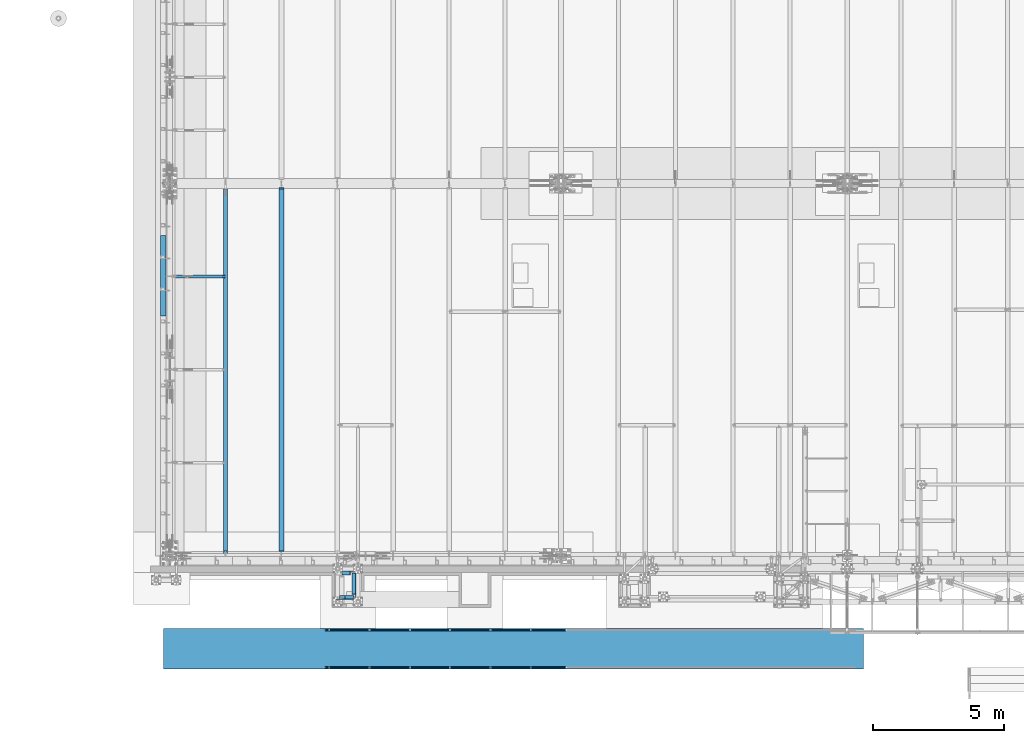
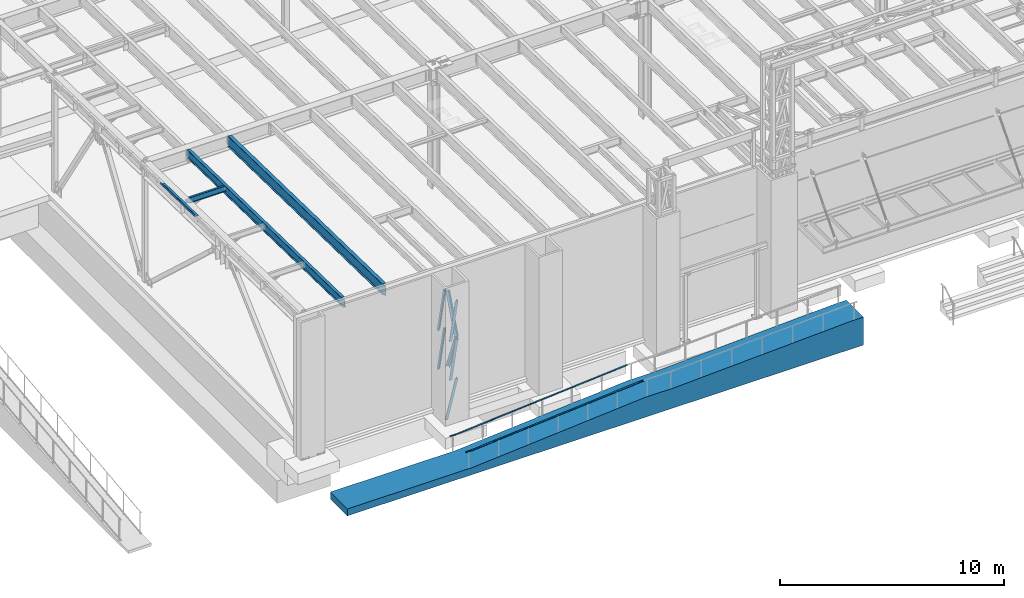
# One storey, part 1036 of 1763: 9 beams, 7 members, 10 elements without a shape of their own.
"""IFC2X3 building model written with IfcOpenShell, lengths in millimetres."""

from ifc_helpers import new_model, si_unit, frame, origin_with_axes, place, context, subcontext, project, spatial, faceted_brep, material, type_object, element, aggregate, save


model = new_model("IFC2X3")

# Units and contexts
model_context = context("Model", 3, precision=1e-05, world=origin_with_axes())
body_context = subcontext(model_context, "Body", "Model", "MODEL_VIEW")
ifc_project = project(units=[si_unit("LENGTHUNIT", "METRE", prefix="MILLI"), si_unit("AREAUNIT", "SQUARE_METRE"), si_unit("VOLUMEUNIT", "CUBIC_METRE"), si_unit("MASSUNIT", "GRAM", prefix="KILO"), si_unit("TIMEUNIT", "SECOND"), si_unit("PLANEANGLEUNIT", "RADIAN"), si_unit("SOLIDANGLEUNIT", "STERADIAN"), si_unit("THERMODYNAMICTEMPERATUREUNIT", "DEGREE_CELSIUS"), si_unit("LUMINOUSINTENSITYUNIT", "LUMEN")], contexts=[model_context])

# Site, building, storey
site_placement = place(None, origin_with_axes())
site = spatial("IfcSite", under=ifc_project, at=site_placement, CompositionType="ELEMENT")
building_placement = place(site_placement, origin_with_axes())
building = spatial("IfcBuilding", under=site, at=building_placement, Name="Undefined", CompositionType="ELEMENT")
storey_placement = place(building_placement, origin_with_axes())
storey = spatial("IfcBuildingStorey", under=building, at=storey_placement, Name="Undefined", CompositionType="ELEMENT", Elevation=0.0)

# Assembly, members
assembly_1_placement = place(storey_placement, origin_with_axes())
assembly_1 = element("IfcElementAssembly", 1, at=assembly_1_placement, inside=storey, Name="FRAME", AssemblyPlace="NOTDEFINED", PredefinedType="RIGID_FRAME")
ifc_material_1 = material(Name="STEEL/A36")
member_type = type_object("IfcMemberType", Name="L6X6X7/8", PredefinedType="NOTDEFINED")
member_1_placement = place(assembly_1_placement, frame((-80755.5622248702, -14360.5242675181, 7209.23504166666), z_axis=(0.0, -1.0, 0.0), x_axis=(0.146884824009466, 0.0, 0.989153602063758)))
member_1 = element("IfcMember", 2, at=member_1_placement, type_object=member_type, material=ifc_material_1, Name="V. BRACE", ObjectType="L6X6X7/8", context=body_context, shape_type="Brep", body=[
    faceted_brep([(9.09494701772928e-13, 76.2000000000007, -76.2000000000844), (0.0, 76.2000000000007, 76.2000000000771), (2139.94349074667, 76.2000000117259, 76.2000000000007), (2139.94349074667, 76.2000000117259, -76.2000000000007), (0.0, 53.9750000000004, 76.2000000000771), (2139.94349074666, 53.9750000118511, 76.2000000000007), (1.81898940354586e-12, 53.9750000000004, -53.9750000000604), (2139.94349074666, 53.9750000118511, -53.9750000000004), (1.81898940354586e-12, -76.2000000000007, -53.9750000000604), (2139.94349074659, -76.199999987497, -53.9750000000004), (9.09494701772928e-13, -76.2000000000007, -76.2000000000844), (2139.94349074659, -76.199999987497, -76.2000000000007)], [[[0, 1, 2, 3]], [[1, 4, 5, 2]], [[4, 6, 7, 5]], [[6, 8, 9, 7]], [[8, 10, 11, 9]], [[10, 0, 3, 11]], [[5, 7, 9, 11, 3, 2]], [[10, 8, 6, 4, 1, 0]]]),
])
member_2_placement = place(assembly_1_placement, frame((-80755.5622248527, -15300.3242675181, 7209.43305011217), z_axis=(0.0, 1.0, 0.0), x_axis=(0.146898270043842, 0.0, 0.989151605295228)))
member_2 = element("IfcMember", 3, at=member_2_placement, type_object=member_type, material=ifc_material_1, Name="V. BRACE", ObjectType="L6X6X7/8", context=body_context, shape_type="Brep", body=[
    faceted_brep([(9.09494701772928e-13, 76.2000000000007, -76.2000000000844), (0.0, 76.2000000000007, 76.2000000000771), (2139.74763009919, 76.2000000046246, 76.2000000000007), (2139.74763009919, 76.2000000046246, -76.2000000000007), (0.0, 53.9750000000004, 76.2000000000771), (2139.7476300992, 53.9750000047788, 76.2000000000007), (1.81898940354586e-12, 53.9750000000004, -53.9750000000604), (2139.7476300992, 53.9750000047788, -53.9750000000004), (1.81898940354586e-12, -76.2000000000007, -53.9750000000604), (2139.74763009929, -76.1999999943509, -53.9750000000004), (9.09494701772928e-13, -76.2000000000007, -76.2000000000844), (2139.74763009929, -76.1999999943509, -76.2000000000007)], [[[0, 1, 2, 3]], [[1, 4, 5, 2]], [[4, 6, 7, 5]], [[6, 8, 9, 7]], [[8, 10, 11, 9]], [[10, 0, 3, 11]], [[5, 7, 9, 11, 3, 2]], [[10, 8, 6, 4, 1, 0]]]),
])
member_3_placement = place(assembly_1_placement, frame((-80755.5622248673, -14360.5242675181, 9325.96736126562), z_axis=(0.0, -1.0, 0.0), x_axis=(0.147752139006393, 0.0, 0.989024421042795)))
member_3 = element("IfcMember", 4, at=member_3_placement, type_object=member_type, material=ifc_material_1, Name="V. BRACE", ObjectType="L6X6X7/8", context=body_context, shape_type="Brep", body=[
    faceted_brep([(9.09494701772928e-13, 76.2000000000007, -76.2000000000844), (0.0, 76.2000000000007, 76.2000000000771), (2127.3818867065, 76.2000000039116, 76.2000000000007), (2127.3818867065, 76.2000000039116, -76.2000000000007), (0.0, 53.9750000000004, 76.2000000000771), (2127.3818867065, 53.9750000039785, 76.2000000000007), (1.81898940354586e-12, 53.9750000000004, -53.9750000000604), (2127.3818867065, 53.9750000039785, -53.9750000000004), (1.81898940354586e-12, -76.2000000000007, -53.9750000000604), (2127.38188670648, -76.1999999956752, -53.9750000000004), (9.09494701772928e-13, -76.2000000000007, -76.2000000000844), (2127.38188670648, -76.1999999956752, -76.2000000000007)], [[[0, 1, 2, 3]], [[1, 4, 5, 2]], [[4, 6, 7, 5]], [[6, 8, 9, 7]], [[8, 10, 11, 9]], [[10, 0, 3, 11]], [[5, 7, 9, 11, 3, 2]], [[10, 8, 6, 4, 1, 0]]]),
])
member_4_placement = place(assembly_1_placement, frame((-80755.5622248673, -15300.3242675181, 9325.96736126562), z_axis=(0.0, 1.0, 0.0), x_axis=(0.147752139006393, 0.0, 0.989024421042795)))
member_4 = element("IfcMember", 5, at=member_4_placement, type_object=member_type, material=ifc_material_1, Name="V. BRACE", ObjectType="L6X6X7/8", context=body_context, shape_type="Brep", body=[
    faceted_brep([(9.09494701772928e-13, 76.2000000000007, -76.2000000000844), (0.0, 76.2000000000007, 76.2000000000771), (2127.3818867065, 76.2000000039116, 76.2000000000007), (2127.3818867065, 76.2000000039116, -76.2000000000007), (0.0, 53.9750000000004, 76.2000000000771), (2127.3818867065, 53.9750000039785, 76.2000000000007), (1.81898940354586e-12, 53.9750000000004, -53.9750000000604), (2127.3818867065, 53.9750000039785, -53.9750000000004), (1.81898940354586e-12, -76.2000000000007, -53.9750000000604), (2127.38188670648, -76.1999999956752, -53.9750000000004), (9.09494701772928e-13, -76.2000000000007, -76.2000000000844), (2127.38188670648, -76.1999999956752, -76.2000000000007)], [[[0, 1, 2, 3]], [[1, 4, 5, 2]], [[4, 6, 7, 5]], [[6, 8, 9, 7]], [[8, 10, 11, 9]], [[10, 0, 3, 11]], [[5, 7, 9, 11, 3, 2]], [[10, 8, 6, 4, 1, 0]]]),
])
member_5_placement = place(assembly_1_placement, frame((-80365.0371272139, -15224.1242675181, 9354.542188), z_axis=(-1.0, 0.0, 0.0), x_axis=(0.0, 0.354716320047586, 0.934973974125429)))
member_5 = element("IfcMember", 6, at=member_5_placement, type_object=member_type, material=ifc_material_1, Name="V. BRACE", ObjectType="L6X6X7/8", context=body_context, shape_type="Brep", body=[
    faceted_brep([(1.81898940354586e-12, -76.2000000000007, -53.9750000000604), (9.09494701772928e-13, -76.2000000000007, -76.2000000000844), (2219.80276448099, -76.1999999997752, -76.1999999999971), (2219.80276448099, -76.1999999997752, -53.9750000000058), (1.81898940354586e-12, 53.9750000000004, -53.9750000000604), (2219.80276448098, 53.9750000001222, -53.9750000000058), (0.0, 53.9750000000004, 76.2000000000771), (2219.80276448098, 53.9750000001222, 76.1999999999971), (0.0, 76.2000000000007, 76.2000000000771), (2219.80276448098, 76.2000000001062, 76.1999999999971), (9.09494701772928e-13, 76.2000000000007, -76.2000000000844), (2219.80276448098, 76.2000000001062, -76.1999999999971)], [[[0, 1, 2, 3]], [[4, 0, 3, 5]], [[6, 4, 5, 7]], [[8, 6, 7, 9]], [[1, 0, 4, 6, 8, 10]], [[1, 10, 11, 2]], [[7, 5, 3, 2, 11, 9]], [[10, 8, 9, 11]]]),
])
member_6_placement = place(assembly_1_placement, frame((-80365.0371272139, -14436.724, 7238.22190623797), z_axis=(-1.0, 0.0, 0.0), x_axis=(0.0, -0.357374206981423, 0.933961281951452)))
member_6 = element("IfcMember", 7, at=member_6_placement, type_object=member_type, material=ifc_material_1, Name="V. BRACE", ObjectType="L6X6X7/8", context=body_context, shape_type="Brep", body=[
    faceted_brep([(1.81898940354586e-12, -76.2000000000007, -53.9750000000604), (9.09494701772928e-13, -76.2000000000007, -76.2000000000844), (2203.29349780015, -76.2000000014305, -76.1999999999971), (2203.29349780015, -76.2000000014305, -53.9750000000058), (1.81898940354586e-12, 53.9750000000004, -53.9750000000604), (2203.29349780012, 53.9749999985361, -53.9750000000058), (0.0, 53.9750000000004, 76.2000000000771), (2203.29349780012, 53.9749999985361, 76.1999999999971), (0.0, 76.2000000000007, 76.2000000000771), (2203.29349780012, 76.1999999985292, 76.1999999999971), (9.09494701772928e-13, 76.2000000000007, -76.2000000000844), (2203.29349780012, 76.1999999985292, -76.1999999999971)], [[[0, 1, 2, 3]], [[4, 0, 3, 5]], [[6, 4, 5, 7]], [[8, 6, 7, 9]], [[1, 0, 4, 6, 8, 10]], [[1, 10, 11, 2]], [[7, 5, 3, 2, 11, 9]], [[10, 8, 9, 11]]]),
])
member_7_placement = place(assembly_1_placement, frame((-80984.1622736983, -15300.3242675181, 5067.30000004768), z_axis=(0.0, 1.0, 0.0), x_axis=(0.24567789390124, 0.0, 0.969351521610324)))
member_7 = element("IfcMember", 8, at=member_7_placement, type_object=member_type, material=ifc_material_1, Name="V. BRACE", ObjectType="L6X6X7/8", context=body_context, shape_type="Brep", body=[
    faceted_brep([(58.6183505265708, 76.1999999992549, -76.2000000000007), (58.6183505265708, 76.1999999992549, 76.2000000000007), (2209.90630573572, 76.1999999841646, 76.2000000000007), (2209.90630573572, 76.1999999841646, -76.2000000000007), (58.6200965849985, 53.9749999993364, 76.2000000000007), (2209.90630573575, 53.9749999842461, 76.2000000000007), (58.6200965849985, 53.9749999993364, -53.9750000000004), (2209.90630573575, 53.9749999842461, -53.9750000000004), (58.6303234986481, -76.2000000000844, -53.9750000000004), (2209.9063057359, -76.2000000151747, -53.9750000000004), (58.6303234986481, -76.2000000000844, -76.2000000000007), (2209.9063057359, -76.2000000151747, -76.2000000000007)], [[[0, 1, 2, 3]], [[1, 4, 5, 2]], [[4, 6, 7, 5]], [[6, 8, 9, 7]], [[8, 10, 11, 9]], [[10, 0, 3, 11]], [[5, 7, 9, 11, 3, 2]], [[10, 8, 6, 4, 1, 0]]]),
])
aggregate(assembly_1, [member_1, member_2, member_3, member_4, member_5, member_6, member_7])

# Assembly, beam
assembly_2_placement = place(storey_placement, origin_with_axes())
assembly_2 = element("IfcElementAssembly", 9, at=assembly_2_placement, inside=storey, Name="HANDRAIL", AssemblyPlace="NOTDEFINED", PredefinedType="RIGID_FRAME")
beam_type_1 = type_object("IfcBeamType", PredefinedType="NOTDEFINED")
beam_1_placement = place(assembly_2_placement, frame((-78410.0559481149, -17957.80011631, 5324.44658406821), z_axis=(0.0, 1.0, 0.0), x_axis=(0.996872552035352, 0.0, 0.0790260400027984)))
beam_1 = element("IfcBeam", 10, at=beam_1_placement, type_object=beam_type_1, material=ifc_material_1, Name="HANDRAIL", context=body_context, shape_type="Brep", body=[
    faceted_brep([(-5.82076609134674e-11, 9.52499999999418, -25.4000000000015), (-5.82076609134674e-11, 9.52499999999418, 25.4000000000015), (6115.12472622086, 9.52499999904467, 25.4000000000015), (6115.12472622086, 9.52499999904467, -25.4000000000015), (2.91038304567337e-11, -9.52499999999418, 25.4000000000015), (6115.12472622092, -9.52500000095279, 25.4000000000015), (2.91038304567337e-11, -9.52499999999418, -25.4000000000015), (6115.12472622092, -9.52500000095279, -25.4000000000015)], [[[0, 1, 2, 3]], [[1, 4, 5, 2]], [[4, 6, 7, 5]], [[6, 0, 3, 7]], [[5, 7, 3, 2]], [[6, 4, 1, 0]]]),
])
aggregate(assembly_2, [beam_1])

assembly_3_placement = place(storey_placement, origin_with_axes())
assembly_3 = element("IfcElementAssembly", 11, at=assembly_3_placement, inside=storey, Name="HANDRAIL", AssemblyPlace="NOTDEFINED", PredefinedType="RIGID_FRAME")
beam_2_placement = place(assembly_3_placement, frame((-78410.0559481149, -17957.80011631, 5324.44658406821), z_axis=(0.0, -1.0, 0.0), x_axis=(-0.996872552986944, 0.0, -0.0790260279989651)))
beam_2 = element("IfcBeam", 12, at=beam_2_placement, type_object=beam_type_1, material=ifc_material_1, Name="HANDRAIL", context=body_context, shape_type="Brep", body=[
    faceted_brep([(2.91038304567337e-11, -9.52499999999418, -25.4000000000015), (2.91038304567337e-11, -9.52499999999418, 25.4000000000015), (-5.82076609134674e-11, 9.52499999999418, 25.4000000000015), (-5.82076609134674e-11, 9.52499999999418, -25.4000000000015), (2752.56020641666, 9.52500132581008, 25.4000000000015), (2752.56020641666, 9.52500132581008, -25.4000000000015), (2751.80632371394, -9.5249986745639, -25.4000000000015), (2751.80632371394, -9.5249986745639, 25.4000000000015), (3057.15833942076, -14.6210830027685, 25.4000000000015), (3057.15833942076, -14.6210830027685, -25.4000000000015), (3055.65293161498, -33.6115081517291, 25.4000000000015), (3055.65293161498, -33.6115081517291, -25.4000000000015)], [[[0, 1, 2, 3]], [[3, 2, 4, 5]], [[1, 0, 6, 7]], [[5, 4, 8, 9]], [[4, 2, 1, 7, 10, 8]], [[7, 6, 11, 10]], [[6, 0, 3, 5, 9, 11]], [[10, 11, 9, 8]]]),
])
aggregate(assembly_3, [beam_2])

assembly_4_placement = place(storey_placement, origin_with_axes())
assembly_4 = element("IfcElementAssembly", 13, at=assembly_4_placement, inside=storey, Name="HANDRAIL", AssemblyPlace="NOTDEFINED", PredefinedType="RIGID_FRAME")
beam_3_placement = place(assembly_4_placement, frame((-78410.0559481149, -16535.40011631, 5324.44658406821), z_axis=(0.0, 1.0, 0.0), x_axis=(0.996872552035352, 0.0, 0.0790260400027984)))
beam_3 = element("IfcBeam", 14, at=beam_3_placement, type_object=beam_type_1, material=ifc_material_1, Name="HANDRAIL", context=body_context, shape_type="Brep", body=[
    faceted_brep([(-5.82076609134674e-11, 9.52499999999418, -25.4000000000015), (-5.82076609134674e-11, 9.52499999999418, 25.4000000000015), (6115.12472622086, 9.52499999904467, 25.4000000000015), (6115.12472622086, 9.52499999904467, -25.4000000000015), (2.91038304567337e-11, -9.52499999999418, 25.4000000000015), (6115.12472622092, -9.52500000095279, 25.4000000000015), (2.91038304567337e-11, -9.52499999999418, -25.4000000000015), (6115.12472622092, -9.52500000095279, -25.4000000000015)], [[[0, 1, 2, 3]], [[1, 4, 5, 2]], [[4, 6, 7, 5]], [[6, 0, 3, 7]], [[5, 7, 3, 2]], [[6, 4, 1, 0]]]),
])
aggregate(assembly_4, [beam_3])

assembly_5_placement = place(storey_placement, origin_with_axes())
assembly_5 = element("IfcElementAssembly", 15, at=assembly_5_placement, inside=storey, Name="HANDRAIL", AssemblyPlace="NOTDEFINED", PredefinedType="RIGID_FRAME")
beam_4_placement = place(assembly_5_placement, frame((-78410.0559481149, -16535.40011631, 5324.44658406821), z_axis=(0.0, -1.0, 0.0), x_axis=(-0.996872552986944, 0.0, -0.0790260279989651)))
beam_4 = element("IfcBeam", 16, at=beam_4_placement, type_object=beam_type_1, material=ifc_material_1, Name="HANDRAIL", context=body_context, shape_type="Brep", body=[
    faceted_brep([(2.91038304567337e-11, -9.52499999999418, -25.4000000000015), (2.91038304567337e-11, -9.52499999999418, 25.4000000000015), (-5.82076609134674e-11, 9.52499999999418, 25.4000000000015), (-5.82076609134674e-11, 9.52499999999418, -25.4000000000015), (2752.56020641666, 9.52500132581008, 25.4000000000015), (2752.56020641666, 9.52500132581008, -25.4000000000015), (2751.80632371394, -9.5249986745639, -25.4000000000015), (2751.80632371394, -9.5249986745639, 25.4000000000015), (3057.15833942076, -14.6210830027685, 25.4000000000015), (3057.15833942076, -14.6210830027685, -25.4000000000015), (3055.65293161498, -33.6115081517291, 25.4000000000015), (3055.65293161498, -33.6115081517291, -25.4000000000015)], [[[0, 1, 2, 3]], [[3, 2, 4, 5]], [[1, 0, 6, 7]], [[5, 4, 8, 9]], [[4, 2, 1, 7, 10, 8]], [[7, 6, 11, 10]], [[6, 0, 3, 5, 9, 11]], [[10, 11, 9, 8]]]),
])
aggregate(assembly_5, [beam_4])

assembly_6_placement = place(storey_placement, origin_with_axes())
assembly_6 = element("IfcElementAssembly", 17, at=assembly_6_placement, inside=storey, Name="BEAM", AssemblyPlace="NOTDEFINED", PredefinedType="REINFORCEMENT_UNIT")
ifc_material_2 = material(Name="CONCRETE/5000")
beam_type_2 = type_object("IfcBeamType", PredefinedType="NOTDEFINED")
beam_5_placement = place(assembly_6_placement, frame((-60984.8372736984, -17246.60011631, 4572.0), z_axis=(0.0, 0.0, 1.0), x_axis=(-1.0, 0.0, 0.0)))
beam_5 = element("IfcBeam", 18, at=beam_5_placement, type_object=beam_type_2, material=ifc_material_2, Name="BEAM", context=body_context, shape_type="Brep", body=[
    faceted_brep([(9753.60077661704, -762.0, 325.419901930823), (9753.60077661704, 762.0, 325.419901930823), (609.601583354837, 762.0, 762.0), (609.601583354837, -762.0, 762.0), (11277.6004219581, -762.0, 325.416947332848), (11277.6004219581, 762.0, 325.416947332848), (20169.1877141989, -762.0, -379.450424738618), (20169.1877141989, 762.0, -379.450424738618), (26619.1990700789, -762.0, -379.45033537152), (26619.2, 762.0, -379.45033537152), (0.0, -762.0, -762.0), (0.0, -762.0, 762.0), (0.0, 762.0, 762.0), (0.0, 762.0, -762.0), (26619.2, 762.0, -762.0), (26619.2, -762.0, -762.0)], [[[0, 1, 2, 3]], [[4, 5, 1, 0]], [[6, 7, 5, 4]], [[8, 9, 7, 6]], [[10, 11, 12, 13]], [[10, 13, 14, 15]], [[4, 0, 3, 11, 10, 15, 8, 6]], [[12, 11, 3, 2]], [[14, 13, 12, 2, 1, 5, 7, 9]], [[15, 14, 9, 8]]]),
])
aggregate(assembly_6, [beam_5])

assembly_7_placement = place(storey_placement, origin_with_axes())
assembly_7 = element("IfcElementAssembly", 19, at=assembly_7_placement, inside=storey, Name="BEAM", AssemblyPlace="NOTDEFINED", PredefinedType="RIGID_FRAME")
beam_type_3 = type_object("IfcBeamType", PredefinedType="NOTDEFINED")
beam_6_placement = place(assembly_7_placement, frame((-87516.7242736983, -3056.58778276706, 11985.0308434697), z_axis=(0.0, -0.999781542838788, 0.0209013539966307), x_axis=(-1.0, 0.0, 0.0)))
beam_6 = element("IfcBeam", 20, at=beam_6_placement, type_object=beam_type_3, material=ifc_material_1, Name="BENT_PLATE", context=body_context, shape_type="Brep", body=[
    faceted_brep([(0.0, -3.17499999999927, -1523.99999999999), (0.0, -3.17499999999927, 1524.0), (0.0, 3.17499999999927, 1524.0), (0.0, 3.17499999999927, -1523.99999999999), (207.962982177749, 3.17499999952452, 1524.00000000123), (207.96298217772, 3.17500000052678, -1524.00000000122), (201.612982177714, -3.17499999947904, -1524.00000000123), (201.612982177743, -3.1750000004813, 1524.00000000122), (207.962982177734, -123.82500358932, 1524.00000000118), (207.962982177734, -123.825003588276, -1524.00000000127), (201.612982177729, -123.82500358932, 1524.00000000118), (201.612982177729, -123.825003588276, -1524.00000000127)], [[[0, 1, 2, 3]], [[3, 2, 4, 5]], [[1, 0, 6, 7]], [[5, 4, 8, 9]], [[4, 2, 1, 7, 10, 8]], [[7, 6, 11, 10]], [[6, 0, 3, 5, 9, 11]], [[10, 11, 9, 8]]]),
])
aggregate(assembly_7, [beam_6])

assembly_8_placement = place(storey_placement, origin_with_axes())
assembly_8 = element("IfcElementAssembly", 21, at=assembly_8_placement, inside=storey, Name="BEAM", AssemblyPlace="NOTDEFINED", PredefinedType="RIGID_FRAME")
ifc_material_3 = material(Name="STEEL/A992")
beam_type_4 = type_object("IfcBeamType", Name="W18X35", PredefinedType="NOTDEFINED")
beam_7_placement = place(assembly_8_placement, frame((-85249.0944165555, -13720.7116289294, 11979.324245716), z_axis=(0.0, 0.0209013539966291, 0.999781542838788), x_axis=(0.0, 0.999781542776098, -0.0209013569953182)))
beam_7 = element("IfcBeam", 22, at=beam_7_placement, type_object=beam_type_4, material=ifc_material_3, Name="BEAM", ObjectType="W18X35", context=body_context, shape_type="Brep", body=[
    faceted_brep([(13974.580277659, 3.96875, -214.312500004775), (13974.580277659, 3.96867178435787, -225.425000004783), (13974.580274698, 76.1999999999971, -225.425000004785), (13974.5802746981, 76.1999999999971, -214.312500004777), (14071.1654982667, 3.96875, -214.312500004808), (14071.3978153366, 3.96950006484985, -225.425000004816), (33.8048670859043, -3.96875, -214.312500000182), (33.8048670859043, -76.1999999999971, -214.312500000182), (13974.5802808897, -76.1999999999971, -214.312500004775), (13974.580277928, -3.96875, -214.312500004777), (188.074466454267, 3.96875, 214.312500000111), (188.074466454267, 76.1999999999971, 214.312500000111), (13968.2302810943, 76.1999999999971, 214.312499995571), (13968.2302810943, 3.96875, 214.312499995571), (188.074466454271, -76.1999999999971, 225.425000000121), (188.074466454271, 76.1999999999971, 225.425000000121), (188.074466454256, 3.96875, 180.714997673294), (188.074466454256, -3.96875, 180.714997673294), (188.074466454267, -3.96875, 214.312500000111), (188.074466454267, -76.1999999999971, 214.312500000111), (187.107736531665, 3.96875, 175.854918155239), (187.107736531665, -3.96875, 175.854918155239), (184.35472263118, 3.96875, 171.734741687076), (184.35472263118, -3.96875, 171.734741687076), (180.234546163016, 3.96875, 168.981727786593), (180.234546163016, -3.96875, 168.981727786593), (175.374466644955, 3.96875, 168.014997864004), (175.374466644955, -3.96875, 168.014997864004), (25.811957837479, 3.96875, 168.014997864053), (25.811957837479, -3.96875, 168.014997864053), (33.8048670859043, 3.96875, -214.312500000182), (33.8048670859043, 76.1999999999971, -214.312500000182), (34.0371841557462, 76.1999999999971, -225.425000000192), (34.0371841557462, -76.1999999999971, -225.425000000192), (13974.5802808897, -76.1999999999971, -225.425000004785), (13974.580277928, -3.96883425187843, -225.425000004783), (14164.8479638763, -3.96875, -214.312500004837), (14165.0802809461, -3.96882644141442, -225.425000004847), (14165.0802809461, 3.96950006484985, -225.425000004847), (14164.8479638763, 3.96875, -214.312500004837), (14164.6992949974, 3.96875, -207.201171861256), (14156.8496190457, 3.96875, 168.27499987722), (14156.8496190457, -3.96875, 168.27499987722), (14164.6992925723, -3.96875, -207.201055860374), (13976.0702013856, -3.96875, 169.241729799809), (13971.9500249174, -3.96875, 171.994743700292), (13969.1970110169, -3.96875, 176.114920168457), (13968.2302810943, -3.96875, 180.974999686512), (13968.2302810943, -3.96875, 214.312499995571), (13980.9302809036, -3.96875, 168.274999877216), (13968.2302810943, -76.1999999999971, 214.312499995571), (13968.2302810943, -76.1999999999971, 225.424999995581), (13968.2302810943, 76.1999999999971, 225.424999995581), (13968.2302810943, 3.96875, 180.974999686512), (13969.1970110169, 3.96875, 176.114920168457), (13971.9500249174, 3.96875, 171.994743700292), (13976.0702013856, 3.96875, 169.241729799809), (13980.9302809036, 3.96875, 168.274999877216)], [[[0, 1, 2, 3]], [[4, 5, 1, 0]], [[6, 7, 8, 9]], [[10, 11, 12, 13]], [[14, 15, 11, 10, 16, 17, 18, 19]], [[17, 16, 20, 21]], [[21, 20, 22, 23]], [[23, 22, 24, 25]], [[25, 24, 26, 27]], [[27, 26, 28, 29]], [[30, 31, 32, 33, 7, 6, 29, 28]], [[7, 33, 34, 8]], [[8, 34, 35, 9]], [[36, 9, 35, 37]], [[38, 39, 40, 41, 42, 43, 36, 37]], [[44, 45, 46, 47, 48, 18, 17, 21, 23, 25, 27, 29, 6, 9, 36, 43, 42, 49]], [[19, 18, 48, 50]], [[14, 19, 50, 51]], [[15, 14, 51, 52]], [[11, 15, 52, 12]], [[51, 50, 48, 47, 53, 13, 12, 52]], [[46, 54, 53, 47]], [[45, 55, 54, 46]], [[44, 56, 55, 45]], [[49, 57, 56, 44]], [[42, 41, 57, 49]], [[40, 39, 4, 0, 30, 28, 26, 24, 22, 20, 16, 10, 13, 53, 54, 55, 56, 57, 41]], [[31, 30, 0, 3]], [[32, 31, 3, 2]], [[38, 37, 35, 34, 33, 32, 2, 1, 5]], [[39, 38, 5, 4]]]),
])
aggregate(assembly_8, [beam_7])

assembly_9_placement = place(storey_placement, origin_with_axes())
assembly_9 = element("IfcElementAssembly", 23, at=assembly_9_placement, inside=storey, Name="BEAM", AssemblyPlace="NOTDEFINED", PredefinedType="RIGID_FRAME")
beam_type_5 = type_object("IfcBeamType", Name="W12X22", PredefinedType="NOTDEFINED")
beam_8_placement = place(assembly_9_placement, frame((-87375.4372736983, -3086.10000001336, 11826.8971298615), z_axis=(0.0, 0.0, 1.0), x_axis=(1.0, 0.0, 0.0)))
beam_8 = element("IfcBeam", 24, at=beam_8_placement, type_object=beam_type_5, material=ifc_material_3, Name="BEAM", ObjectType="W12X22", context=body_context, shape_type="Brep", body=[
    faceted_brep([(20.6374999999971, -3.17499999999927, -123.824999999781), (20.6374999999971, 3.17499999999927, -123.824999999781), (198.437500190732, 3.17500001932785, -123.824999999781), (198.437500190732, -3.17500000000018, -123.824999999781), (203.297579708771, 3.17500001940971, -124.791729922368), (203.297579708771, -3.17500000000018, -124.791729922368), (207.417756176932, 3.17500001964163, -127.544743822846), (207.417756176932, -3.17500000000018, -127.544743822846), (210.170770077413, 3.17500001998906, -131.664920290999), (210.170770077413, -3.17500000000018, -131.664920290999), (211.137499999997, -3.17500000000018, -136.524999809046), (211.137499999997, 3.17500002039924, -136.524999809046), (211.137499999997, 3.17500004775593, -144.4625), (211.137499999997, 50.8000000000002, -144.4625), (211.137499999997, 50.8000000000002, -155.575000000001), (211.137499999997, -50.8000000000002, -155.575000000001), (211.137499999997, -50.8000000000002, -144.4625), (211.137499999997, -3.17500000000018, -144.4625), (2033.47410714286, 50.7999999999993, 144.4625), (2033.47410714286, 3.17499999999927, 144.4625), (211.137499999997, 3.17500000000018, 144.4625), (211.137499999997, 50.8000000000002, 144.4625), (198.437500190732, -3.17500000000018, 111.12500000022), (198.437500190732, 3.17499999968732, 111.12500000022), (20.6374999999971, 3.17499999999927, 111.12500000022), (20.6374999999971, -3.17499999999927, 111.12500000022), (203.297579708771, -3.17500000000018, 112.091729922808), (203.297579708771, 3.17499999960637, 112.091729922808), (207.417756176932, -3.17500000000018, 114.844743823285), (207.417756176932, 3.17499999937718, 114.844743823285), (210.170770077413, -3.17500000000018, 118.964920291439), (210.170770077413, 3.1749999990343, 118.964920291439), (211.137499999997, -3.17500000000018, 123.824999809485), (211.137499999997, 3.17499999862866, 123.824999809485), (2033.47410714286, -50.7999999999993, 155.575000000001), (2033.47410714286, 50.7999999999993, 155.575000000001), (211.137499999997, 50.8000000000002, 155.575000000001), (211.137499999997, -50.8000000000002, 155.575000000001), (2033.47410714286, -50.7999999999993, 144.4625), (211.137499999997, -50.8000000000002, 144.4625), (2033.47410714286, -3.17499999999927, 144.4625), (211.137499999997, -3.17500000000018, 144.4625), (2033.47410714286, -3.17499999999927, 136.265001487105), (2033.47410714286, 3.17499999999927, 136.265001487105), (2034.44083706544, -3.17499999999927, 131.404921969059), (2034.44083706544, 3.17499999999927, 131.404921969059), (2037.19385096592, -3.17499999999927, 127.284745500905), (2037.19385096592, 3.17499999999927, 127.284745500905), (2041.31402743408, -3.17499999999927, 124.531731600428), (2041.31402743408, 3.17499999999927, 124.531731600428), (2046.17410695212, -3.17499999999927, 123.56500167784), (2046.17410695212, 3.17499999999927, 123.56500167784), (2109.67410714286, -3.17499999999927, 123.56500167784), (2109.67410714286, 3.17499999999927, 123.56500167784), (2109.67410714286, -3.17499999999927, -144.4625), (2109.67410714286, -50.7999999999993, -144.4625), (2109.67410714286, -50.7999999999993, -155.575000000001), (2109.67410714286, 50.7999999999993, -155.575000000001), (2109.67410714286, 50.7999999999993, -144.4625), (2109.67410714286, 3.17499999999927, -144.4625)], [[[0, 1, 2, 3]], [[3, 2, 4, 5]], [[5, 4, 6, 7]], [[7, 6, 8, 9]], [[10, 11, 12, 13, 14, 15, 16, 17]], [[9, 8, 11, 10]], [[18, 19, 20, 21]], [[22, 23, 24, 25]], [[26, 27, 23, 22]], [[28, 29, 27, 26]], [[30, 31, 29, 28]], [[32, 33, 31, 30]], [[34, 35, 36, 37]], [[38, 34, 37, 39]], [[40, 38, 39, 41]], [[37, 36, 21, 20, 33, 32, 41, 39]], [[35, 18, 21, 36]], [[34, 38, 40, 42, 43, 19, 18, 35]], [[44, 45, 43, 42]], [[46, 47, 45, 44]], [[48, 49, 47, 46]], [[50, 51, 49, 48]], [[52, 53, 51, 50]], [[54, 55, 56, 57, 58, 59, 53, 52]], [[55, 54, 17, 16]], [[56, 55, 16, 15]], [[57, 56, 15, 14]], [[58, 57, 14, 13]], [[59, 58, 13, 12]], [[6, 4, 2, 1, 24, 23, 27, 29, 31, 33, 20, 19, 43, 45, 47, 49, 51, 53, 59, 12, 11, 8]], [[25, 24, 1, 0]], [[54, 52, 50, 48, 46, 44, 42, 40, 41, 32, 30, 28, 26, 22, 25, 0, 3, 5, 7, 9, 10, 17]]]),
])
aggregate(assembly_9, [beam_8])

assembly_10_placement = place(storey_placement, origin_with_axes())
assembly_10 = element("IfcElementAssembly", 25, at=assembly_10_placement, inside=storey, Name="BEAM", AssemblyPlace="NOTDEFINED", PredefinedType="RIGID_FRAME")
beam_type_6 = type_object("IfcBeamType", Name="W24X55", PredefinedType="NOTDEFINED")
beam_9_placement = place(assembly_10_placement, frame((-83122.7515594126, -13722.2711313756, 11904.7280453544), z_axis=(0.0, 0.0209013539966291, 0.999781542838788), x_axis=(0.0, 0.999781542776098, -0.0209013569953182)))
beam_9 = element("IfcBeam", 26, at=beam_9_placement, type_object=beam_type_6, material=ifc_material_3, Name="BEAM", ObjectType="W24X55", context=body_context, shape_type="Brep", body=[
    faceted_brep([(163.919115448763, -4.76249999999709, -287.337500000287), (164.18462067144, -4.76200008392334, -300.037500000297), (183.361759226002, -4.76239140644611, -300.037500000302), (183.361759226023, -4.76249999999709, -287.337500000292), (183.36176814427, -88.8999999999942, -287.337500000292), (183.361768144267, -88.8999999999942, -300.037500000302), (14168.1999673346, 5.06250000001455, -300.037500004912), (14068.1661142181, 5.06250000001455, -300.037500004879), (14067.9006089955, 5.06250000001455, -287.337500005347), (14167.9344621119, 5.06250000001455, -287.3375000049), (14034.9273925426, 88.8999999999942, -287.337500004856), (183.361749302443, 88.8999999999942, -287.337500000292), (183.361758221041, 4.76239139326208, -287.337500002202), (14167.9344621119, 4.76249999999709, -287.3375000049), (14034.9273989147, 5.06262332902406, -287.337500005337), (14034.9273989147, 5.06237371187308, -300.037500004868), (14034.9273925426, 88.8999999999942, -300.037500004868), (183.361749302438, 88.8999999999942, -300.037500000302), (183.361758221019, 4.76261468007579, -300.037500000304), (164.18462067144, 4.76299991607084, -300.037500000297), (163.919115448763, 4.76249999999709, -287.337500000287), (37.1568705442241, 4.76299991607084, -300.037500000257), (36.8913653215495, 4.76250000000073, -287.337500000245), (183.361748773876, 4.76250000000073, 287.337500000169), (183.361748773876, 88.9000000000015, 287.337500000169), (13971.4274064739, 88.8999999999942, 287.337499995627), (13971.4274064739, 4.76249999999709, 287.337499995627), (36.0948805793596, 4.76249999999709, -249.238979286023), (25.8065222748755, 4.76249999999709, 242.887500000506), (170.661748964563, 4.76249999999709, 242.887500000461), (175.521828482621, 4.76249999999709, 243.854229923048), (179.642004950787, 4.76249999999709, 246.607243823531), (182.395018851274, 4.76249999999709, 250.727420291694), (183.361748773865, 4.76249999999709, 255.58749980975), (13971.4274064739, 4.76250977152085, 248.977497550664), (13972.3941363965, 4.7625093152019, 244.117418032611), (13975.147150297, 4.76250892841199, 239.997241564446), (13979.2673267651, 4.76250866999908, 237.244227663961), (13984.1274062832, 4.76250857934065, 236.27749774137), (14156.9878072637, 4.76249999999709, 236.277497741372), (14156.9878072637, -4.76249999999709, 236.277497741372), (14167.9344621119, -4.76249999999709, -287.3375000049), (14167.9344621119, -5.06236354894645, -287.3375000049), (14168.1999673346, -5.06261314581207, -300.037500004912), (14034.927399722, -5.06237365734705, -287.337500004856), (14034.927399722, -5.06262327449804, -300.037500004866), (14034.9274060935, -88.8999999999942, -287.337500004856), (14034.9274060935, -88.8999999999942, -300.037500004868), (37.1568705442241, -4.76200008392334, -300.037500000257), (36.8913653215495, -4.76250000000073, -287.337500000245), (36.0948840789624, -4.76249999999709, -249.239146683703), (25.8065222748755, -4.76249999999709, 242.887500000506), (152.834272402093, -4.76249999999709, 242.887500000465), (170.661748964563, -4.76249999999709, 242.887500000461), (175.521828482621, -4.76249999999709, 243.854229923048), (179.642004950787, -4.76249999999709, 246.607243823531), (182.395018851274, -4.76249999999709, 250.727420291694), (183.361748773865, -4.76249999999709, 255.58749980975), (183.361748773879, -88.9000000000015, 300.03750000018), (183.361748773879, 88.9000000000015, 300.03750000018), (183.361748773876, -4.76250000000073, 287.337500000169), (183.361748773876, -88.9000000000015, 287.337500000169), (13971.4274064739, -4.76249999999709, 287.337499995627), (13971.4274064739, -88.8999999999942, 287.337499995627), (13971.4274064739, -88.8999999999942, 300.037499995638), (13971.4274064739, 88.8999999999942, 300.037499995638), (13971.4274064739, -4.76249999999709, 248.977497550664), (13972.3941363965, -4.76249999999709, 244.117418032611), (13975.147150297, -4.76249999999709, 239.997241564446), (13979.2673267651, -4.76249999999709, 237.244227663961), (13984.1274062832, -4.76249999999709, 236.27749774137)], [[[0, 1, 2, 3]], [[4, 3, 2, 5]], [[6, 7, 8, 9]], [[10, 11, 12, 13, 9, 8, 14]], [[7, 15, 14, 8]], [[14, 15, 16, 10]], [[17, 11, 10, 16]], [[11, 17, 18, 12]], [[12, 18, 19, 20]], [[21, 22, 20, 19]], [[23, 24, 25, 26]], [[13, 12, 20, 22, 27, 28, 29, 30, 31, 32, 33, 23, 26, 34, 35, 36, 37, 38, 39]], [[6, 9, 13, 39, 40, 41, 42, 43]], [[43, 42, 44, 45]], [[46, 47, 45, 44]], [[47, 46, 4, 5]], [[1, 48, 21, 19, 18, 17, 16, 15, 7, 6, 43, 45, 47, 5, 2]], [[1, 0, 49, 48]], [[50, 51, 28, 27, 22, 21, 48, 49]], [[52, 53, 29, 28, 51]], [[54, 30, 29, 53]], [[55, 31, 30, 54]], [[56, 32, 31, 55]], [[57, 33, 32, 56]], [[58, 59, 24, 23, 33, 57, 60, 61]], [[61, 60, 62, 63]], [[58, 61, 63, 64]], [[59, 58, 64, 65]], [[24, 59, 65, 25]], [[64, 63, 62, 66, 34, 26, 25, 65]], [[67, 35, 34, 66]], [[68, 36, 35, 67]], [[69, 37, 36, 68]], [[70, 38, 37, 69]], [[40, 39, 38, 70]], [[69, 68, 67, 66, 62, 60, 57, 56, 55, 54, 53, 52, 51, 50, 49, 0, 3, 41, 40, 70]], [[46, 44, 42, 41, 3, 4]]]),
])
aggregate(assembly_10, [beam_9])

save(model, "model.ifc")
